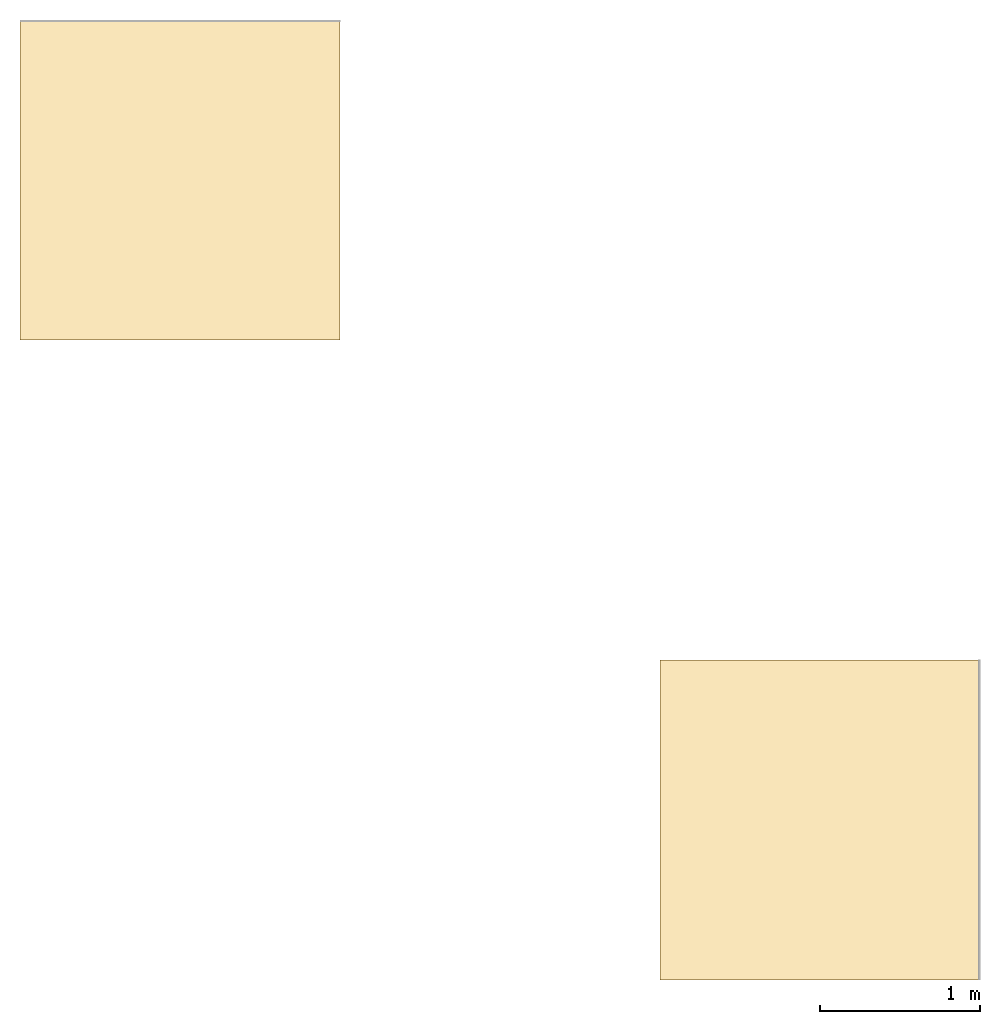
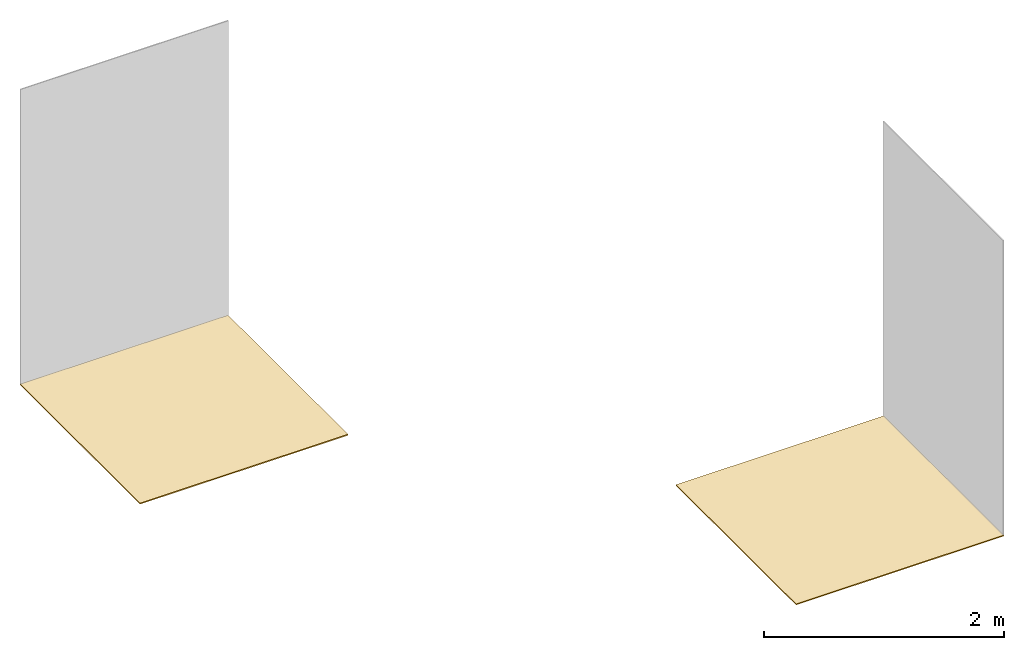
# One storey, part 2 of 2: 2 coverings.
"""IFC2X3 building model written with IfcOpenShell, lengths in millimetres."""

from ifc_helpers import new_model, entity, si_unit, converted_unit, derived_unit, direction, frame, frame_2d, origin, place, context, subcontext, project, spatial, rectangle, extrude, material, layer, layer_set, layer_usage, element, save


model = new_model("IFC2X3")

# Units and contexts
model_context = context("Model", 3, precision=0.01, world=origin(), true_north=direction((6.12303176911189e-17, 1.0)))
body_context = subcontext(model_context, "Body", "Model", "MODEL_VIEW")
ifc_project = project(units=[si_unit("LENGTHUNIT", "METRE", prefix="MILLI"), si_unit("AREAUNIT", "SQUARE_METRE"), si_unit("VOLUMEUNIT", "CUBIC_METRE"), converted_unit("PLANEANGLEUNIT", "DEGREE", entity("IfcRatioMeasure", 0.0174532925199433), si_unit("PLANEANGLEUNIT", "RADIAN"), dimensions=[0, 0, 0, 0, 0, 0, 0]), si_unit("MASSUNIT", "GRAM", prefix="KILO"), derived_unit("MASSDENSITYUNIT", [(si_unit("MASSUNIT", "GRAM", prefix="KILO"), 1), (si_unit("LENGTHUNIT", "METRE"), -3)]), si_unit("TIMEUNIT", "SECOND"), si_unit("FREQUENCYUNIT", "HERTZ"), si_unit("THERMODYNAMICTEMPERATUREUNIT", "DEGREE_CELSIUS"), derived_unit("THERMALTRANSMITTANCEUNIT", [(si_unit("MASSUNIT", "GRAM", prefix="KILO"), 1), (si_unit("THERMODYNAMICTEMPERATUREUNIT", "KELVIN"), -1), (si_unit("TIMEUNIT", "SECOND"), -3)]), derived_unit("VOLUMETRICFLOWRATEUNIT", [(si_unit("LENGTHUNIT", "METRE"), 3), (si_unit("TIMEUNIT", "SECOND"), -1)]), si_unit("ELECTRICCURRENTUNIT", "AMPERE"), si_unit("ELECTRICVOLTAGEUNIT", "VOLT"), si_unit("POWERUNIT", "WATT"), si_unit("FORCEUNIT", "NEWTON", prefix="KILO"), si_unit("ILLUMINANCEUNIT", "LUX"), si_unit("LUMINOUSFLUXUNIT", "LUMEN"), si_unit("LUMINOUSINTENSITYUNIT", "CANDELA"), derived_unit("USERDEFINED", [(si_unit("MASSUNIT", "GRAM", prefix="KILO"), -1), (si_unit("LENGTHUNIT", "METRE"), -2), (si_unit("TIMEUNIT", "SECOND"), 3), (si_unit("LUMINOUSFLUXUNIT", "LUMEN"), 1)]), derived_unit("LINEARVELOCITYUNIT", [(si_unit("LENGTHUNIT", "METRE"), 1), (si_unit("TIMEUNIT", "SECOND"), -1)]), si_unit("PRESSUREUNIT", "PASCAL"), derived_unit("USERDEFINED", [(si_unit("LENGTHUNIT", "METRE"), -2), (si_unit("MASSUNIT", "GRAM", prefix="KILO"), 1), (si_unit("TIMEUNIT", "SECOND"), -2)])], contexts=[model_context])

# Site, building, storey
site_placement = place(None, origin())
site = spatial("IfcSite", under=ifc_project, at=site_placement, CompositionType="ELEMENT")
building_placement = place(site_placement, origin())
building = spatial("IfcBuilding", under=site, at=building_placement, CompositionType="ELEMENT")
storey_placement = place(building_placement, origin())
storey = spatial("IfcBuildingStorey", under=building, at=storey_placement, Name="Level 1", CompositionType="ELEMENT", Elevation=0.0)

# Coverings
ifc_material_1 = material()
ifc_layer_1 = layer(ifc_material_1, 10.5)
ifc_layer_set_1 = layer_set([ifc_layer_1])
ifc_layer_usage_1 = layer_usage(ifc_layer_set_1, "AXIS3", "POSITIVE", 0.0)
covering_1_placement = place(storey_placement, origin())
element("IfcCovering", 1, at=covering_1_placement, inside=storey, material=ifc_layer_usage_1, PredefinedType="FLOORING", context=body_context, shape_type="SweptSolid", body=[
    extrude(rectangle(XDim=2000.0, YDim=2000.0, at=frame_2d((2.8421709430404e-13, 2.8421709430404e-13), x_axis=(1.0, 0.0))), frame((2527.07742659013, -3501.98267476882, 0.0), z_axis=(0.0, 0.0, -1.0), x_axis=(0.0, 1.0, 0.0)), (0.0, 0.0, 1.0), 10.5),
])
ifc_material_2 = material()
ifc_layer_2 = layer(ifc_material_2, 11.2)
ifc_layer_set_2 = layer_set([ifc_layer_2])
ifc_layer_usage_2 = layer_usage(ifc_layer_set_2, "AXIS3", "POSITIVE", 0.0)
covering_2_placement = place(storey_placement, origin())
element("IfcCovering", 2, at=covering_2_placement, inside=storey, material=ifc_layer_usage_2, PredefinedType="FLOORING", context=body_context, shape_type="SweptSolid", body=[
    extrude(rectangle(XDim=2000.0, YDim=2000.0, at=frame_2d((1.13686837721616e-13, 0.0), x_axis=(1.0, 0.0))), frame((-1472.92257340987, 498.017325231178, 0.0), z_axis=(0.0, 0.0, -1.0), x_axis=(0.0, 1.0, 0.0)), (0.0, 0.0, 1.0), 11.2),
])

save(model, "model.ifc")
